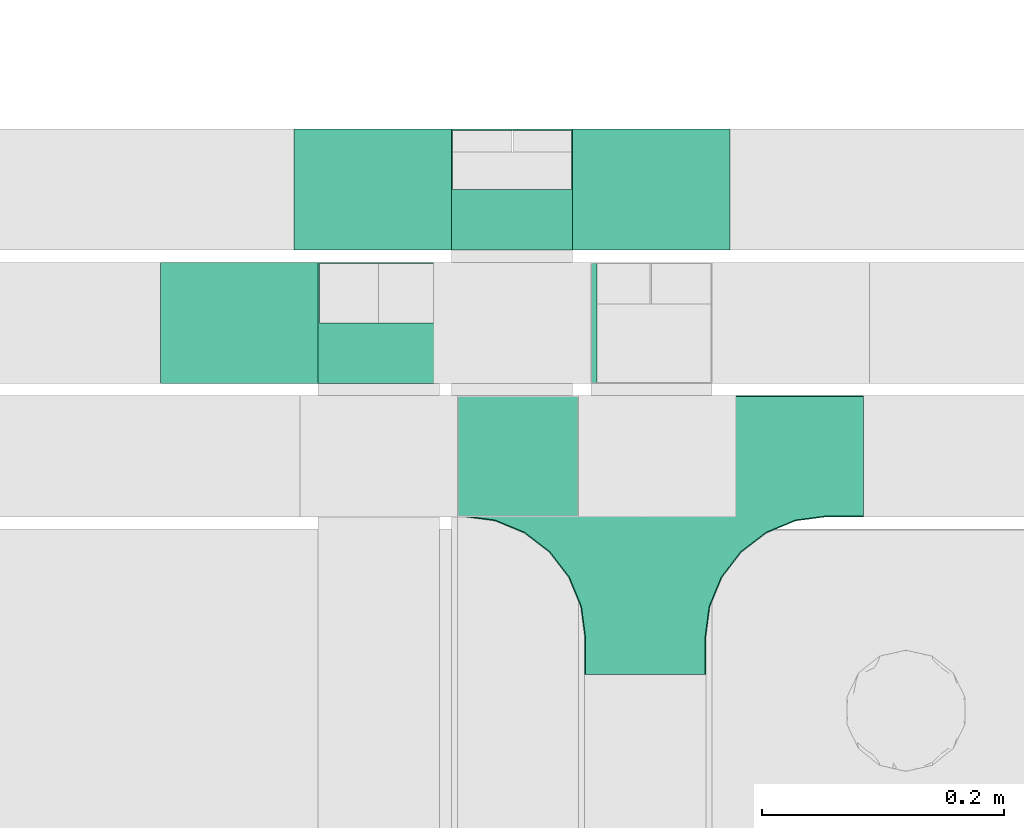
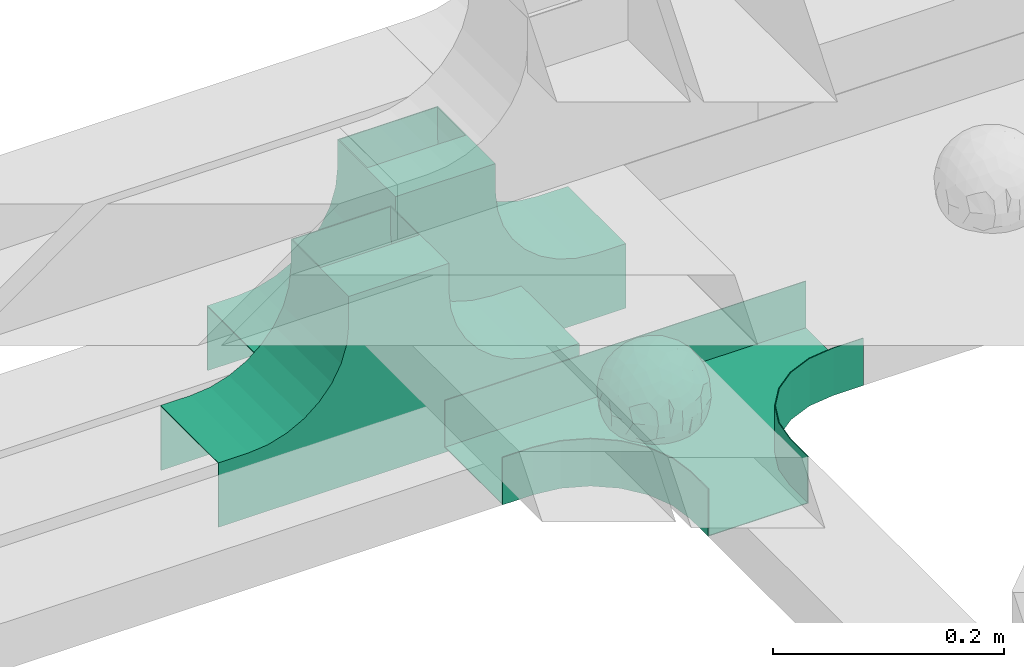
# One storey, part 9 of 32: 3 flow fittings.
"""IFC2X3 building model written with IfcOpenShell, lengths in millimetres."""

from ifc_helpers import new_model, entity, si_unit, converted_unit, derived_unit, direction, frame, frame_2d, origin, origin_2d_with_axis, place, context, subcontext, project, spatial, polyline, circle_curve, parameter, trimmed, segment, composite_curve, rectangle, outline, extrude, faceted_brep, source, transform, mapped, material, material_list, type_object, type_shapes, element, save


model = new_model("IFC2X3")

# Units and contexts
model_context = context("Model", 3, precision=0.01, world=origin(), true_north=direction((6.12303176911189e-17, 1.0)))
body_context = subcontext(model_context, "Body", "Model", "MODEL_VIEW")
ifc_project = project(units=[si_unit("LENGTHUNIT", "METRE", prefix="MILLI"), si_unit("AREAUNIT", "SQUARE_METRE"), si_unit("VOLUMEUNIT", "CUBIC_METRE"), converted_unit("PLANEANGLEUNIT", "DEGREE", entity("IfcRatioMeasure", 0.0174532925199433), si_unit("PLANEANGLEUNIT", "RADIAN"), dimensions=[0, 0, 0, 0, 0, 0, 0]), si_unit("MASSUNIT", "GRAM", prefix="KILO"), derived_unit("MASSDENSITYUNIT", [(si_unit("MASSUNIT", "GRAM", prefix="KILO"), 1), (si_unit("LENGTHUNIT", "METRE"), -3)]), derived_unit("MOMENTOFINERTIAUNIT", [(si_unit("LENGTHUNIT", "METRE"), 4)]), si_unit("TIMEUNIT", "SECOND"), si_unit("FREQUENCYUNIT", "HERTZ"), si_unit("THERMODYNAMICTEMPERATUREUNIT", "DEGREE_CELSIUS"), derived_unit("THERMALTRANSMITTANCEUNIT", [(si_unit("MASSUNIT", "GRAM", prefix="KILO"), 1), (si_unit("THERMODYNAMICTEMPERATUREUNIT", "KELVIN"), -1), (si_unit("TIMEUNIT", "SECOND"), -3)]), derived_unit("VOLUMETRICFLOWRATEUNIT", [(si_unit("LENGTHUNIT", "METRE"), 3), (si_unit("TIMEUNIT", "SECOND"), -1)]), derived_unit("MASSFLOWRATEUNIT", [(si_unit("MASSUNIT", "GRAM", prefix="KILO"), 1), (si_unit("TIMEUNIT", "SECOND"), -1)]), derived_unit("ROTATIONALFREQUENCYUNIT", [(si_unit("TIMEUNIT", "SECOND"), -1)]), si_unit("ELECTRICCURRENTUNIT", "AMPERE"), si_unit("ELECTRICVOLTAGEUNIT", "VOLT"), si_unit("POWERUNIT", "WATT"), si_unit("FORCEUNIT", "NEWTON", prefix="KILO"), si_unit("ILLUMINANCEUNIT", "LUX"), si_unit("LUMINOUSFLUXUNIT", "LUMEN"), si_unit("LUMINOUSINTENSITYUNIT", "CANDELA"), derived_unit("USERDEFINED", [(si_unit("MASSUNIT", "GRAM", prefix="KILO"), -1), (si_unit("LENGTHUNIT", "METRE"), -2), (si_unit("TIMEUNIT", "SECOND"), 3), (si_unit("LUMINOUSFLUXUNIT", "LUMEN"), 1)]), derived_unit("LINEARVELOCITYUNIT", [(si_unit("LENGTHUNIT", "METRE"), 1), (si_unit("TIMEUNIT", "SECOND"), -1)]), si_unit("PRESSUREUNIT", "PASCAL"), derived_unit("USERDEFINED", [(si_unit("LENGTHUNIT", "METRE"), -2), (si_unit("MASSUNIT", "GRAM", prefix="KILO"), 1), (si_unit("TIMEUNIT", "SECOND"), -2)]), derived_unit("LINEARFORCEUNIT", [(si_unit("MASSUNIT", "GRAM", prefix="KILO"), 1), (si_unit("LENGTHUNIT", "METRE"), 1), (si_unit("TIMEUNIT", "SECOND"), -2), (si_unit("LENGTHUNIT", "METRE"), -1)]), derived_unit("PLANARFORCEUNIT", [(si_unit("MASSUNIT", "GRAM", prefix="KILO"), 1), (si_unit("LENGTHUNIT", "METRE"), 1), (si_unit("TIMEUNIT", "SECOND"), -2), (si_unit("LENGTHUNIT", "METRE"), -2)])], contexts=[model_context])

# Site, building, storey
site_placement = place(None, origin())
site = spatial("IfcSite", under=ifc_project, at=site_placement, CompositionType="ELEMENT")
building_placement = place(site_placement, origin())
building = spatial("IfcBuilding", under=site, at=building_placement, CompositionType="ELEMENT")
storey_placement = place(building_placement, frame((0.0, 0.0, 8100.0)))
storey = spatial("IfcBuildingStorey", under=building, at=storey_placement, CompositionType="ELEMENT", Elevation=8100.0)

# Flow fittings
ifc_material_1 = material()
ifc_material_2 = material()
ifc_material_list_1 = material_list([ifc_material_1, ifc_material_2])
cable_carrier_fitting_type_1 = type_object("IfcCableCarrierFittingType", PredefinedType="NOTDEFINED", material=ifc_material_1)
shared_shape_1 = source(origin(), body_context, "Body", "Brep", [
    faceted_brep([(43.65, -13.62, -20.22), (44.77, 0.0, -22.26), (48.26, -5.6, -11.81), (16.66, 5.33, -46.84), (11.56, -8.33, -47.93), (2.02, 2.7, -49.89), (-7.81, -35.95, -33.86), (-17.21, -38.27, -27.19), (-11.13, -27.32, -40.37), (37.7, -7.25, -32.03), (10.64, 26.52, -41.03), (19.21, 19.84, -41.68), (10.42, 17.81, -45.54), (48.75, 0.0, 0.0), (48.07, 6.52, -12.13), (-37.46, 12.16, -30.81), (-31.35, 12.15, -37.01), (-38.09, 3.52, -32.2), (48.75, 11.13, 0.0), (9.67, 42.57, -24.39), (17.48, 37.97, -27.43), (8.35, 35.36, -34.35), (36.7, 20.43, -27.12), (28.22, 12.58, -39.31), (28.4, 24.01, -33.43), (37.1, 7.75, -32.61), (30.39, 38.11, 0.0), (34.74, 34.64, 0.0), (32.94, 32.13, -19.56), (26.04, 41.58, 0.0), (-44.77, 0.0, -22.26), (-35.92, -8.72, -33.67), (-42.7, -12.19, -22.99), (5.42, -48.76, 0.0), (0.0, -48.78, -10.96), (7.59, -47.43, -13.88), (34.0, -31.65, -18.51), (40.01, -26.24, -14.51), (30.39, -38.11, 0.0), (-47.55, -8.65, -12.8), (43.92, -21.15, 0.0), (-47.55, 8.68, -12.81), (-43.92, 21.15, 0.0), (-41.56, 23.54, -14.78), (-36.7, 20.43, -27.12), (-42.68, 12.16, -23.03), (-0.04, -44.68, -22.44), (43.35, 13.13, -21.19), (-9.67, -42.82, -23.94), (2.93, -38.3, -32.0), (10.58, -32.36, -36.62), (17.48, -37.97, -27.43), (29.42, -14.29, -37.82), (29.26, 0.0, -40.54), (-34.74, 34.64, 0.0), (-35.59, 30.87, -16.74), (16.27, 46.29, 0.0), (15.4, 45.37, -14.3), (10.85, 47.52, 0.0), (-22.09, 42.26, -15.04), (-16.27, 46.29, 0.0), (-15.4, 45.37, -14.3), (-35.57, -30.88, -16.76), (-34.74, -34.64, 0.0), (-41.54, -23.57, -14.78), (-21.2, -29.91, -34.0), (-22.09, -42.26, -15.04), (-28.59, -35.77, -20.07), (27.97, -26.92, -31.51), (26.56, -36.75, -21.06), (-4.7, -12.82, -48.1), (-3.71, -22.05, -44.72), (0.0, -29.85, -40.11), (-8.78, 23.47, -43.27), (-10.71, 12.15, -47.3), (-19.19, 19.81, -41.71), (19.21, -19.84, -41.68), (10.27, -43.25, -22.88), (-16.27, -46.29, 0.0), (-15.42, -45.43, -14.08), (-10.85, -47.52, 0.0), (-21.69, -45.05, 0.0), (-26.04, -41.58, 0.0), (-30.39, -38.11, 0.0), (-26.91, -11.71, -40.48), (-28.57, -22.53, -34.29), (-14.35, 0.55, -47.89), (20.39, 29.7, -34.67), (25.88, 35.56, -23.78), (-1.9, 38.3, -32.09), (-0.04, 44.68, -22.44), (-9.54, 42.67, -24.26), (-10.12, 33.04, -36.14), (-17.21, 38.27, -27.19), (-28.59, 35.77, -20.07), (-30.39, 38.11, 0.0), (-26.04, 41.58, 0.0), (-21.69, 45.05, 0.0), (0.92, 16.99, -47.01), (0.0, 29.85, -40.11), (-28.43, 23.64, -33.66), (22.08, -42.72, -13.7), (0.0, -50.0, 0.0), (-7.98, 47.29, -14.15), (-10.85, 47.52, 0.0), (-5.42, 48.76, 0.0), (-39.09, -31.17, 0.0), (-36.7, -20.43, -27.12), (-20.05, 29.88, -34.71), (48.75, -11.13, 0.0), (36.7, -20.43, -27.12), (39.09, -31.17, 0.0), (43.92, 21.15, 0.0), (41.04, 24.48, -14.72), (21.43, -9.87, -44.08), (19.85, -30.3, -34.47), (26.04, -41.58, 0.0), (8.28, -22.62, -43.82), (-19.19, -19.81, -41.71), (-17.56, -9.66, -45.81), (-29.26, 0.0, -40.54), (-22.28, 8.45, -43.96), (21.69, -45.05, 0.0), (-7.75, -47.32, -14.15), (22.09, 42.36, -14.75), (21.69, 45.05, 0.0), (7.94, 47.25, -14.29), (5.42, 48.76, 0.0), (-43.92, -21.15, 0.0), (-39.09, 31.17, 0.0), (-48.75, 11.13, 0.0), (-48.75, -11.13, 0.0), (-48.75, 0.0, 0.0), (0.0, 50.0, 0.0), (0.0, 48.77, -11.04), (-5.42, -48.76, 0.0), (16.27, -46.29, 0.0), (10.85, -47.52, 0.0), (39.09, 31.17, 0.0), (34.74, -34.64, 0.0), (-43.65, -13.62, 20.22), (-44.77, 0.0, 22.26), (-48.26, -5.6, 11.81), (-16.66, 5.33, 46.84), (-11.56, -8.33, 47.93), (-2.02, 2.7, 49.89), (7.81, -35.95, 33.86), (17.21, -38.27, 27.19), (11.13, -27.32, 40.37), (-37.7, -7.25, 32.03), (-10.64, 26.52, 41.03), (-19.21, 19.84, 41.68), (-10.42, 17.81, 45.54), (-48.07, 6.52, 12.13), (37.46, 12.16, 30.81), (31.35, 12.15, 37.01), (38.09, 3.52, 32.2), (-9.67, 42.57, 24.39), (-17.48, 37.97, 27.43), (-8.35, 35.36, 34.35), (-36.7, 20.43, 27.12), (-28.22, 12.58, 39.31), (-28.4, 24.01, 33.43), (-37.1, 7.75, 32.61), (-32.94, 32.13, 19.56), (44.77, 0.0, 22.26), (35.92, -8.72, 33.67), (42.7, -12.19, 22.99), (0.0, -48.78, 10.96), (-7.59, -47.43, 13.88), (-34.0, -31.65, 18.51), (-40.01, -26.24, 14.51), (47.55, -8.65, 12.8), (47.55, 8.68, 12.81), (41.56, 23.54, 14.78), (36.7, 20.43, 27.12), (42.68, 12.16, 23.03), (0.04, -44.68, 22.44), (-43.35, 13.13, 21.19), (9.67, -42.82, 23.94), (-2.93, -38.3, 32.0), (-10.58, -32.36, 36.62), (-17.48, -37.97, 27.43), (-29.42, -14.29, 37.82), (-29.26, 0.0, 40.54), (35.59, 30.87, 16.74), (-15.4, 45.37, 14.3), (22.09, 42.26, 15.04), (15.4, 45.37, 14.3), (35.57, -30.88, 16.76), (41.54, -23.57, 14.78), (21.2, -29.91, 34.0), (22.09, -42.26, 15.04), (28.59, -35.77, 20.07), (-27.97, -26.92, 31.51), (-26.56, -36.75, 21.06), (4.7, -12.82, 48.1), (3.71, -22.05, 44.72), (0.0, -29.85, 40.11), (8.78, 23.47, 43.27), (10.71, 12.15, 47.3), (19.19, 19.81, 41.71), (-19.21, -19.84, 41.68), (-10.27, -43.25, 22.88), (15.42, -45.43, 14.08), (26.91, -11.71, 40.48), (28.57, -22.53, 34.29), (14.35, 0.55, 47.89), (-20.39, 29.7, 34.67), (-25.88, 35.56, 23.78), (1.9, 38.3, 32.09), (0.04, 44.68, 22.44), (9.54, 42.67, 24.26), (10.12, 33.04, 36.14), (17.21, 38.27, 27.19), (28.59, 35.77, 20.07), (-0.92, 16.99, 47.01), (0.0, 29.85, 40.11), (28.43, 23.64, 33.66), (-22.08, -42.72, 13.7), (7.98, 47.29, 14.15), (36.7, -20.43, 27.12), (20.05, 29.88, 34.71), (-36.7, -20.43, 27.12), (-41.04, 24.48, 14.72), (-21.43, -9.87, 44.08), (-19.85, -30.3, 34.47), (-8.28, -22.62, 43.82), (19.19, -19.81, 41.71), (17.56, -9.66, 45.81), (29.26, 0.0, 40.54), (22.28, 8.45, 43.96), (7.75, -47.32, 14.15), (-22.09, 42.36, 14.75), (-7.94, 47.25, 14.29), (0.0, 48.77, 11.04)], [[[0, 1, 2]], [[3, 4, 5]], [[6, 7, 8]], [[1, 0, 9]], [[10, 11, 12]], [[13, 2, 14]], [[15, 16, 17]], [[14, 18, 13]], [[19, 20, 21]], [[22, 23, 24]], [[1, 9, 25]], [[26, 27, 28, 29]], [[30, 31, 32]], [[33, 34, 35]], [[36, 37, 38]], [[32, 39, 30]], [[2, 40, 0]], [[23, 22, 25]], [[41, 42, 43]], [[44, 15, 45]], [[46, 35, 34]], [[25, 22, 47]], [[31, 30, 17]], [[48, 49, 46]], [[50, 51, 49]], [[52, 53, 9]], [[43, 54, 55]], [[56, 57, 58]], [[59, 60, 61]], [[62, 63, 64]], [[8, 7, 65]], [[7, 66, 67]], [[68, 36, 69]], [[70, 5, 4]], [[8, 71, 72]], [[73, 74, 75]], [[68, 76, 52]], [[77, 46, 49]], [[78, 79, 80]], [[7, 6, 48]], [[67, 81, 82, 83]], [[84, 85, 31]], [[85, 65, 67]], [[70, 86, 5]], [[23, 3, 11]], [[21, 87, 10]], [[21, 20, 87]], [[28, 24, 88]], [[19, 89, 90]], [[91, 90, 89]], [[91, 92, 93]], [[94, 95, 96, 97]], [[98, 99, 10]], [[100, 16, 44]], [[77, 51, 101]], [[33, 102, 34]], [[103, 91, 61]], [[93, 59, 61]], [[104, 105, 103]], [[106, 64, 63]], [[107, 31, 85]], [[100, 94, 108]], [[108, 93, 92]], [[43, 55, 44]], [[0, 40, 37]], [[2, 13, 109]], [[2, 1, 14]], [[110, 9, 0]], [[2, 109, 40]], [[37, 40, 111]], [[47, 14, 1]], [[112, 14, 47]], [[113, 112, 47]], [[112, 18, 14]], [[47, 22, 113]], [[52, 9, 110]], [[53, 25, 9]], [[25, 47, 1]], [[23, 25, 53]], [[68, 52, 110]], [[76, 4, 114]], [[51, 115, 69]], [[50, 115, 51]], [[110, 36, 68]], [[3, 23, 53]], [[23, 11, 24]], [[52, 76, 114]], [[98, 12, 5]], [[11, 87, 24]], [[24, 28, 22]], [[87, 88, 24]], [[36, 116, 69]], [[28, 27, 113]], [[114, 3, 53]], [[76, 115, 117]], [[70, 4, 117]], [[118, 84, 119]], [[119, 70, 118]], [[120, 16, 121]], [[37, 36, 110]], [[116, 36, 38]], [[116, 122, 69]], [[34, 123, 46]], [[10, 87, 11]], [[87, 20, 88]], [[12, 98, 10]], [[10, 99, 21]], [[74, 5, 86]], [[73, 75, 108]], [[124, 56, 125]], [[124, 29, 88]], [[89, 21, 99]], [[21, 89, 19]], [[92, 89, 99]], [[89, 92, 91]], [[126, 127, 58]], [[88, 29, 28]], [[20, 57, 124]], [[88, 20, 124]], [[57, 20, 19]], [[73, 92, 99]], [[92, 73, 108]], [[99, 98, 73]], [[74, 86, 121]], [[73, 98, 74]], [[5, 74, 98]], [[100, 108, 75]], [[94, 93, 108]], [[86, 120, 121]], [[100, 44, 55]], [[75, 16, 100]], [[17, 16, 120]], [[31, 17, 120]], [[17, 30, 45]], [[84, 31, 120]], [[31, 107, 32]], [[41, 45, 30]], [[43, 44, 45]], [[107, 64, 32]], [[39, 64, 128]], [[30, 39, 41]], [[129, 43, 42]], [[41, 130, 42]], [[43, 45, 41]], [[62, 83, 63]], [[95, 94, 55]], [[100, 55, 94]], [[64, 107, 62]], [[131, 39, 128]], [[64, 106, 128]], [[85, 62, 107]], [[67, 83, 62]], [[39, 32, 64]], [[130, 41, 132]], [[59, 97, 60]], [[133, 127, 134]], [[59, 94, 97]], [[104, 61, 60]], [[94, 59, 93]], [[126, 134, 127]], [[126, 58, 57]], [[19, 90, 126]], [[134, 105, 133]], [[126, 90, 134]], [[103, 90, 91]], [[105, 134, 103]], [[90, 103, 134]], [[119, 120, 86]], [[84, 118, 85]], [[65, 85, 118]], [[62, 85, 67]], [[8, 65, 118]], [[67, 65, 7]], [[71, 118, 70]], [[8, 72, 6]], [[49, 6, 72]], [[6, 49, 48]], [[50, 49, 72]], [[77, 49, 51]], [[101, 69, 122]], [[123, 34, 135]], [[101, 122, 136]], [[137, 77, 136]], [[78, 81, 66]], [[7, 79, 66]], [[67, 66, 81]], [[79, 7, 48]], [[35, 137, 33]], [[123, 80, 79]], [[135, 34, 102]], [[35, 46, 77]], [[80, 123, 135]], [[46, 123, 48]], [[117, 50, 72]], [[115, 76, 68]], [[117, 72, 71]], [[4, 76, 117]], [[39, 132, 41]], [[39, 131, 132]], [[137, 35, 77]], [[124, 57, 56]], [[126, 57, 19]], [[103, 61, 104]], [[61, 91, 93]], [[77, 101, 136]], [[51, 69, 101]], [[28, 113, 22]], [[112, 113, 138]], [[16, 75, 121]], [[74, 121, 75]], [[66, 79, 78]], [[123, 79, 48]], [[0, 37, 110]], [[37, 111, 139, 38]], [[29, 124, 125]], [[115, 50, 117]], [[69, 115, 68]], [[120, 119, 84]], [[70, 119, 86]], [[11, 3, 12]], [[5, 12, 3]], [[118, 71, 8]], [[117, 71, 70]], [[3, 114, 4]], [[53, 52, 114]], [[27, 138, 113]], [[45, 15, 17]], [[44, 16, 15]], [[55, 54, 95]], [[43, 129, 54]], [[140, 141, 142]], [[143, 144, 145]], [[146, 147, 148]], [[141, 140, 149]], [[150, 151, 152]], [[132, 142, 153]], [[154, 155, 156]], [[153, 130, 132]], [[157, 158, 159]], [[160, 161, 162]], [[141, 149, 163]], [[95, 54, 164, 96]], [[165, 166, 167]], [[135, 168, 169]], [[170, 171, 83]], [[167, 172, 165]], [[142, 141, 153]], [[161, 160, 163]], [[173, 112, 174]], [[175, 154, 176]], [[177, 169, 168]], [[163, 160, 178]], [[166, 165, 156]], [[179, 180, 177]], [[181, 182, 180]], [[183, 184, 149]], [[174, 27, 185]], [[60, 186, 104]], [[187, 56, 188]], [[189, 139, 190]], [[148, 147, 191]], [[147, 192, 193]], [[194, 170, 195]], [[196, 145, 144]], [[148, 197, 198]], [[199, 200, 201]], [[194, 202, 183]], [[203, 177, 180]], [[136, 204, 137]], [[147, 146, 179]], [[193, 122, 116, 38]], [[205, 206, 166]], [[206, 191, 193]], [[196, 207, 145]], [[161, 143, 151]], [[159, 208, 150]], [[159, 158, 208]], [[164, 162, 209]], [[157, 210, 211]], [[212, 211, 210]], [[212, 213, 214]], [[215, 26, 29, 125]], [[216, 217, 150]], [[218, 155, 175]], [[203, 182, 219]], [[135, 102, 168]], [[220, 212, 188]], [[214, 187, 188]], [[58, 127, 220]], [[111, 190, 139]], [[221, 166, 206]], [[218, 215, 222]], [[222, 214, 213]], [[174, 185, 175]], [[171, 140, 128]], [[132, 131, 142]], [[142, 128, 140]], [[223, 149, 140]], [[142, 131, 128]], [[171, 128, 106]], [[178, 153, 141]], [[42, 153, 178]], [[224, 42, 178]], [[42, 130, 153]], [[178, 160, 224]], [[183, 149, 223]], [[184, 163, 149]], [[163, 178, 141]], [[161, 163, 184]], [[194, 183, 223]], [[202, 144, 225]], [[182, 226, 195]], [[181, 226, 182]], [[223, 170, 194]], [[143, 161, 184]], [[161, 151, 162]], [[183, 202, 225]], [[216, 152, 145]], [[151, 208, 162]], [[162, 164, 160]], [[208, 209, 162]], [[170, 82, 195]], [[164, 54, 224]], [[225, 143, 184]], [[202, 226, 227]], [[196, 144, 227]], [[228, 205, 229]], [[229, 196, 228]], [[230, 155, 231]], [[171, 170, 223]], [[82, 170, 83]], [[82, 81, 195]], [[168, 232, 177]], [[150, 208, 151]], [[208, 158, 209]], [[152, 216, 150]], [[150, 217, 159]], [[200, 145, 207]], [[199, 201, 222]], [[233, 60, 97]], [[233, 96, 209]], [[210, 159, 217]], [[159, 210, 157]], [[213, 210, 217]], [[210, 213, 212]], [[234, 105, 104]], [[209, 96, 164]], [[158, 186, 233]], [[209, 158, 233]], [[186, 158, 157]], [[199, 213, 217]], [[213, 199, 222]], [[217, 216, 199]], [[200, 207, 231]], [[199, 216, 200]], [[145, 200, 216]], [[218, 222, 201]], [[215, 214, 222]], [[207, 230, 231]], [[218, 175, 185]], [[201, 155, 218]], [[156, 155, 230]], [[166, 156, 230]], [[156, 165, 176]], [[205, 166, 230]], [[166, 221, 167]], [[173, 176, 165]], [[174, 175, 176]], [[221, 190, 167]], [[172, 190, 40]], [[165, 172, 173]], [[138, 174, 112]], [[173, 18, 112]], [[174, 176, 173]], [[189, 38, 139]], [[26, 215, 185]], [[218, 185, 215]], [[190, 221, 189]], [[109, 172, 40]], [[190, 111, 40]], [[206, 189, 221]], [[193, 38, 189]], [[172, 167, 190]], [[18, 173, 13]], [[187, 125, 56]], [[133, 105, 235]], [[187, 215, 125]], [[58, 188, 56]], [[215, 187, 214]], [[234, 235, 105]], [[234, 104, 186]], [[157, 211, 234]], [[235, 127, 133]], [[234, 211, 235]], [[220, 211, 212]], [[127, 235, 220]], [[211, 220, 235]], [[229, 230, 207]], [[205, 228, 206]], [[191, 206, 228]], [[189, 206, 193]], [[148, 191, 228]], [[193, 191, 147]], [[197, 228, 196]], [[148, 198, 146]], [[180, 146, 198]], [[146, 180, 179]], [[181, 180, 198]], [[203, 180, 182]], [[219, 195, 81]], [[232, 168, 33]], [[219, 81, 78]], [[80, 203, 78]], [[136, 122, 192]], [[147, 204, 192]], [[193, 192, 122]], [[204, 147, 179]], [[169, 80, 135]], [[232, 137, 204]], [[33, 168, 102]], [[169, 177, 203]], [[137, 232, 33]], [[177, 232, 179]], [[227, 181, 198]], [[226, 202, 194]], [[227, 198, 197]], [[144, 202, 227]], [[172, 13, 173]], [[172, 109, 13]], [[80, 169, 203]], [[233, 186, 60]], [[234, 186, 157]], [[220, 188, 58]], [[188, 212, 214]], [[203, 219, 78]], [[182, 195, 219]], [[164, 224, 160]], [[42, 224, 129]], [[155, 201, 231]], [[200, 231, 201]], [[192, 204, 136]], [[232, 204, 179]], [[140, 171, 223]], [[171, 106, 63, 83]], [[96, 233, 97]], [[226, 181, 227]], [[195, 226, 194]], [[230, 229, 205]], [[196, 229, 207]], [[151, 143, 152]], [[145, 152, 143]], [[228, 197, 148]], [[227, 197, 196]], [[143, 225, 144]], [[184, 183, 225]], [[54, 129, 224]], [[176, 154, 156]], [[175, 155, 154]], [[185, 27, 26]], [[174, 138, 27]]]),
    faceted_brep([(-53.41, -124.12, 25.0), (-50.0, -150.0, 25.0), (-50.0, -180.0, 25.0), (-49.2, -180.0, 25.0), (-49.2, -150.0, 25.0), (-52.63, -123.91, 25.0), (-62.7, -99.6, 25.0), (-78.72, -78.72, 25.0), (-99.6, -62.7, 25.0), (-123.91, -52.63, 25.0), (-150.0, -49.2, 25.0), (-180.0, -49.2, 25.0), (-180.0, -50.0, 25.0), (-150.0, -50.0, 25.0), (-124.12, -53.41, 25.0), (-100.0, -63.4, 25.0), (-79.29, -79.29, 25.0), (-63.4, -100.0, 25.0), (180.0, -50.0, 25.0), (180.0, -49.2, 25.0), (150.0, -49.2, 25.0), (123.91, -52.63, 25.0), (99.6, -62.7, 25.0), (78.72, -78.72, 25.0), (62.7, -99.6, 25.0), (52.63, -123.91, 25.0), (49.2, -150.0, 25.0), (49.2, -180.0, 25.0), (50.0, -180.0, 25.0), (50.0, -150.0, 25.0), (53.41, -124.12, 25.0), (63.4, -100.0, 25.0), (79.29, -79.29, 25.0), (100.0, -63.4, 25.0), (124.12, -53.41, 25.0), (150.0, -50.0, 25.0), (180.0, 49.2, 25.0), (180.0, 50.0, 25.0), (-180.0, 50.0, 25.0), (-180.0, 49.2, 25.0), (-180.0, -50.0, -25.0), (-180.0, 50.0, -25.0), (180.0, 50.0, -25.0), (180.0, -50.0, -25.0), (150.0, -50.0, -25.0), (124.12, -53.41, -25.0), (100.0, -63.4, -25.0), (79.29, -79.29, -25.0), (63.4, -100.0, -25.0), (53.41, -124.12, -25.0), (50.0, -150.0, -25.0), (50.0, -180.0, -25.0), (-50.0, -180.0, -25.0), (-50.0, -150.0, -25.0), (-53.41, -124.12, -25.0), (-63.4, -100.0, -25.0), (-79.29, -79.29, -25.0), (-100.0, -63.4, -25.0), (-124.12, -53.41, -25.0), (-150.0, -50.0, -25.0), (-50.0, -150.0, -24.2), (49.2, -180.0, -24.2), (-49.2, -180.0, -24.2), (-49.2, -150.0, -24.2), (-150.0, -49.2, -24.2), (-180.0, -49.2, -24.2), (180.0, -49.2, -24.2), (150.0, -49.2, -24.2), (-180.0, 49.2, -24.2), (-150.0, -50.0, -24.2), (150.0, -50.0, -24.2), (180.0, 49.2, -24.2), (49.2, -150.0, -24.2), (50.0, -150.0, -24.2), (-123.91, -52.63, -24.2), (-99.6, -62.7, -24.2), (-78.72, -78.72, -24.2), (-62.7, -99.6, -24.2), (-52.63, -123.91, -24.2), (52.63, -123.91, -24.2), (62.7, -99.6, -24.2), (78.72, -78.72, -24.2), (99.6, -62.7, -24.2), (123.91, -52.63, -24.2)], [[[0, 1, 2, 3, 4, 5, 6, 7, 8, 9, 10, 11, 12, 13, 14, 15, 16, 17]], [[18, 19, 20, 21, 22, 23, 24, 25, 26, 27, 28, 29, 30, 31, 32, 33, 34, 35]], [[36, 37, 38, 39]], [[40, 41, 42, 43, 44, 45, 46, 47, 48, 49, 50, 51, 52, 53, 54, 55, 56, 57, 58, 59]], [[2, 1, 60, 53, 52]], [[3, 2, 52, 51, 28, 27, 61, 62]], [[4, 3, 62, 63]], [[11, 10, 64, 65]], [[20, 19, 66, 67]], [[39, 38, 41, 40, 12, 11, 65, 68]], [[13, 12, 40, 59, 69]], [[18, 35, 70, 44, 43]], [[19, 18, 43, 42, 37, 36, 71, 66]], [[27, 26, 72, 61]], [[29, 28, 51, 50, 73]], [[38, 37, 42, 41]], [[36, 39, 68, 71]], [[68, 65, 64, 74, 75, 76, 77, 78, 63, 62, 61, 72, 79, 80, 81, 82, 83, 67, 66, 71]], [[14, 13, 69, 59, 58]], [[58, 57, 15, 14]], [[15, 57, 56, 16]], [[0, 17, 55, 54]], [[0, 54, 53, 60, 1]], [[55, 17, 16, 56]], [[5, 4, 63, 78]], [[6, 5, 78, 77]], [[7, 6, 77, 76]], [[8, 7, 76, 75]], [[9, 8, 75, 74]], [[10, 9, 74, 64]], [[21, 20, 67, 83]], [[22, 21, 83, 82]], [[23, 22, 82, 81]], [[81, 80, 24, 23]], [[24, 80, 79, 25]], [[79, 72, 26, 25]], [[30, 29, 73, 50, 49]], [[31, 30, 49, 48]], [[31, 48, 47, 32]], [[33, 32, 47, 46]], [[45, 34, 33, 46]], [[34, 45, 44, 70, 35]]]),
])
type_shapes(cable_carrier_fitting_type_1, [shared_shape_1])
flow_fitting_1_placement = place(storey_placement, frame((18181.01, 14542.28, 2590.34)))
element("IfcFlowFitting", 1, at=flow_fitting_1_placement, inside=storey, type_object=cable_carrier_fitting_type_1, material=ifc_material_list_1, Name="470_DKC_S5_T", context=body_context, shape_type="MappedRepresentation", body=[
    mapped(shared_shape_1, transform((0.0, 0.0, 0.0), scale=1.0)),
])
ifc_material_list_2 = material_list([ifc_material_2, ifc_material_2, ifc_material_2, ifc_material_2, ifc_material_2])
cable_carrier_fitting_type_2 = type_object("IfcCableCarrierFittingType", Name="470_DKC_S5_TSS cover (flat)", PredefinedType="NOTDEFINED", material=ifc_material_list_2)
shared_shape_2 = source(origin(), body_context, "Body", "SweptSolid", [
    extrude(rectangle(XDim=99.9999999999999, YDim=49.9999999999991, at=origin_2d_with_axis()), frame((0.0, -25.0, 154.0)), (0.0, 0.0, 1.0), 0.999999999999908),
    extrude(outline(composite_curve([segment(polyline([(-72.75, -57.25), (-72.75, -58.25)]), True, "CONTINUOUS"), segment(polyline([(-72.75, -58.25), (-42.75, -58.25)]), True, "CONTINUOUS"), segment(trimmed(circle_curve(frame_2d((-42.75, 42.75), x_axis=(0.0, 1.0)), 101.0), [parameter(180.0)], [parameter(270.0)], True, "PARAMETER"), True, "CONTINUOUS"), segment(polyline([(58.25, 42.75), (58.25, 72.75)]), True, "CONTINUOUS"), segment(polyline([(58.25, 72.75), (57.25, 72.75)]), True, "CONTINUOUS"), segment(polyline([(57.25, 72.75), (57.25, 42.75)]), True, "CONTINUOUS"), segment(trimmed(circle_curve(frame_2d((-42.75, 42.75), x_axis=(0.0, 1.0)), 100.0), [parameter(180.0)], [parameter(270.0)], True, "PARAMETER"), False, "CONTINUOUS"), segment(polyline([(-42.75, -57.25), (-72.75, -57.25)]), True, "CONTINUOUS")], self_intersect=False)), frame((107.25, -50.0, 82.25), z_axis=(0.0, -1.0, 0.0), x_axis=(0.0, 0.0, -1.0)), (0.0, 0.0, -1.0), 100.0),
    extrude(outline(composite_curve([segment(polyline([(57.25, -72.75), (58.25, -72.75)]), True, "CONTINUOUS"), segment(polyline([(58.25, -72.75), (58.25, -42.75)]), True, "CONTINUOUS"), segment(trimmed(circle_curve(frame_2d((-42.75, -42.75), x_axis=(1.0, 0.0)), 101.0), [parameter(4.57999874130747e-13)], [parameter(90.0000000000007)], True, "PARAMETER"), True, "CONTINUOUS"), segment(polyline([(-42.75, 58.25), (-72.75, 58.25)]), True, "CONTINUOUS"), segment(polyline([(-72.75, 58.25), (-72.75, 57.25)]), True, "CONTINUOUS"), segment(polyline([(-72.75, 57.25), (-42.75, 57.25)]), True, "CONTINUOUS"), segment(trimmed(circle_curve(frame_2d((-42.75, -42.75), x_axis=(1.0, 0.0)), 100.0), [parameter(360.0)], [parameter(89.9999999999999)], True, "PARAMETER"), False, "CONTINUOUS"), segment(polyline([(57.25, -42.75), (57.25, -72.75)]), True, "CONTINUOUS")], self_intersect=False)), frame((-107.25, -50.0, 82.25), z_axis=(0.0, 1.0, 0.0), x_axis=(1.0, 0.0, 0.0)), (0.0, 0.0, 1.0), 100.0),
    extrude(outline(composite_curve([segment(polyline([(-50.0, -97.6), (50.0, -97.6)]), True, "CONTINUOUS"), segment(polyline([(50.0, -97.6), (50.0, -67.6)]), True, "CONTINUOUS"), segment(trimmed(circle_curve(frame_2d((150.0, -67.6), x_axis=(1.0, 0.0)), 100.0), [parameter(90.0000000000003)], [parameter(180.0)], True, "PARAMETER"), False, "CONTINUOUS"), segment(polyline([(150.0, 32.4), (180.0, 32.4)]), True, "CONTINUOUS"), segment(polyline([(180.0, 32.4), (180.0, 100.4)]), True, "CONTINUOUS"), segment(polyline([(180.0, 100.4), (-180.0, 100.4)]), True, "CONTINUOUS"), segment(polyline([(-180.0, 100.4), (-180.0, 32.4)]), True, "CONTINUOUS"), segment(polyline([(-180.0, 32.4), (-150.0, 32.4)]), True, "CONTINUOUS"), segment(trimmed(circle_curve(frame_2d((-150.0, -67.6), x_axis=(1.0, 0.0)), 100.0), [parameter(1.01777749806833e-13)], [parameter(90.0000000000002)], True, "PARAMETER"), False, "CONTINUOUS"), segment(polyline([(-50.0, -67.6), (-50.0, -97.6)]), True, "CONTINUOUS")], self_intersect=False)), frame((0.0, -50.0, 57.4), z_axis=(0.0, 1.0, 0.0), x_axis=(1.0, 0.0, 0.0)), (0.0, 0.0, 1.0), 1.0),
    extrude(outline(composite_curve([segment(polyline([(-150.0, -32.4), (-180.0, -32.4)]), True, "CONTINUOUS"), segment(polyline([(-180.0, -32.4), (-180.0, -100.4)]), True, "CONTINUOUS"), segment(polyline([(-180.0, -100.4), (180.0, -100.4)]), True, "CONTINUOUS"), segment(polyline([(180.0, -100.4), (180.0, -32.4)]), True, "CONTINUOUS"), segment(polyline([(180.0, -32.4), (150.0, -32.4)]), True, "CONTINUOUS"), segment(trimmed(circle_curve(frame_2d((150.0, 67.6), x_axis=(1.0, 0.0)), 100.0), [parameter(180.0)], [parameter(270.0)], True, "PARAMETER"), False, "CONTINUOUS"), segment(polyline([(50.0, 67.6), (50.0, 97.6)]), True, "CONTINUOUS"), segment(polyline([(50.0, 97.6), (-50.0, 97.6)]), True, "CONTINUOUS"), segment(polyline([(-50.0, 97.6), (-50.0, 67.6)]), True, "CONTINUOUS"), segment(trimmed(circle_curve(frame_2d((-150.0, 67.6), x_axis=(1.0, 0.0)), 100.0), [parameter(270.0)], [parameter(360.0)], True, "PARAMETER"), False, "CONTINUOUS")], self_intersect=False)), frame((0.0, 49.0, 57.4), z_axis=(0.0, -1.0, 0.0), x_axis=(1.0, 0.0, 0.0)), (0.0, 0.0, -1.0), 1.00000000000003),
])
type_shapes(cable_carrier_fitting_type_2, [shared_shape_2])
flow_fitting_2_placement = place(storey_placement, frame((18071.01, 14762.28, 2595.0)))
element("IfcFlowFitting", 2, at=flow_fitting_2_placement, inside=storey, type_object=cable_carrier_fitting_type_2, material=ifc_material_list_2, Name="470_DKC_S5_cover (flat)", ObjectType="470_DKC_S5_TSS cover (flat)", context=body_context, shape_type="MappedRepresentation", body=[
    mapped(shared_shape_2, transform((0.0, 0.0, 0.0), scale=1.0)),
])
flow_fitting_3_placement = place(storey_placement, frame((17961.01, 14652.28, 2595.0)))
element("IfcFlowFitting", 3, at=flow_fitting_3_placement, inside=storey, type_object=cable_carrier_fitting_type_2, material=ifc_material_2, Name="470_DKC_S5_cover (flat)", ObjectType="470_DKC_S5_TSS cover (flat)", context=body_context, shape_type="MappedRepresentation", body=[
    mapped(shared_shape_2, transform((0.0, 0.0, 0.0), scale=1.0)),
])

save(model, "model.ifc")
